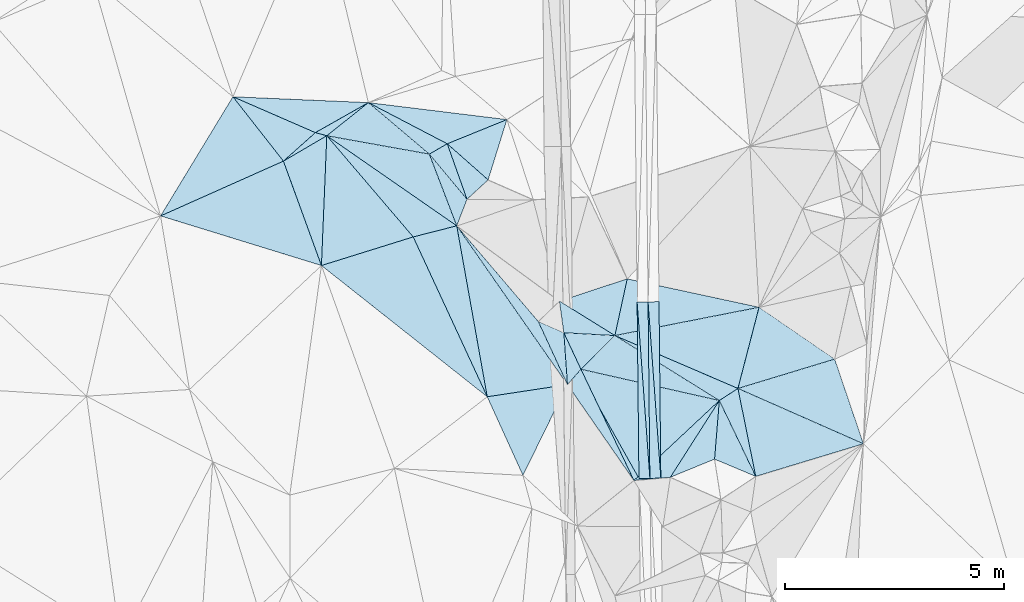
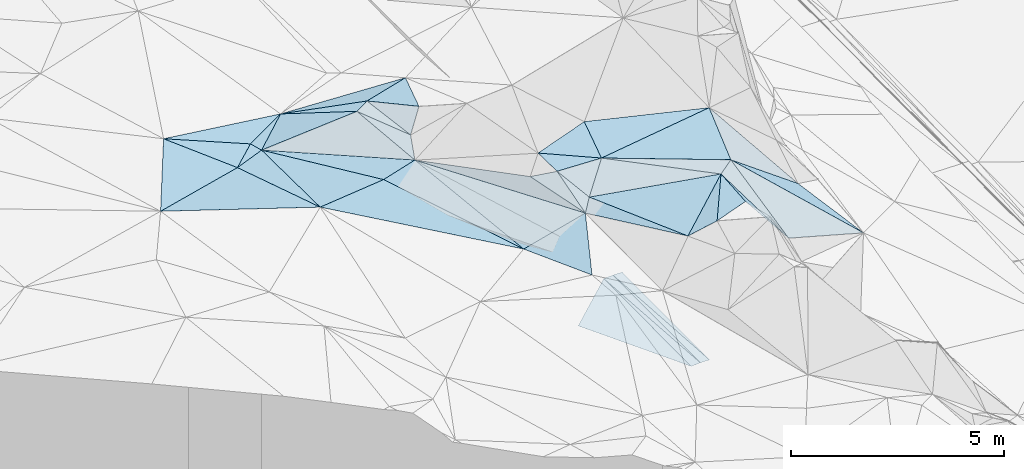
# One storey, part 17 of 275: 45 plates.
"""IFC2X3 building model written with IfcOpenShell, lengths in millimetres."""

import ifcopenshell
import ifcopenshell.guid

model = None  # the IFC model being written
_history = None  # IfcOwnerHistory: only IFC2X3 demands one
_inside = {}  # id of a spatial element -> (the spatial element, [elements in it])
_under = {}  # id of a project, library or spatial element -> (it, [spatial elements below it])
_declared = {}  # id of a project -> (the project, [libraries it declares])
_typed = {}  # id of a type object -> (the type object, [elements of that type])
_made_of = {}  # id of a material, layer set ... -> (it, [elements and type objects made of it])


def new_model(schema):
    """Start an empty IFC model of exactly this schema.

    Asked for "IFC4X3", IfcOpenShell would pick the latest addendum, in which some entities
    have other attributes; the version numbers below select the first issue.
    IFC2X3 requires an IfcOwnerHistory on every rooted entity: one is made here for all.
    """
    global model, _history
    if schema == "IFC4X3":
        model = ifcopenshell.file(schema_version=(4, 3, 0, 0))
    else:
        model = ifcopenshell.file(schema=schema)
    _inside.clear()
    _under.clear()
    _declared.clear()
    _typed.clear()
    _made_of.clear()
    _history = None
    if model.schema == "IFC2X3":
        org = make("IfcOrganization", Name="unknown")
        user = make(
            "IfcPersonAndOrganization",
            ThePerson=make("IfcPerson", FamilyName="unknown"),
            TheOrganization=org,
        )
        app = make(
            "IfcApplication",
            ApplicationDeveloper=org,
            Version="unknown",
            ApplicationFullName="unknown",
            ApplicationIdentifier="unknown",
        )
        _history = make(
            "IfcOwnerHistory",
            OwningUser=user,
            OwningApplication=app,
            ChangeAction="ADDED",
            CreationDate=0,
        )
    return model


def make(cls, **values):
    """One entity of the class cls with the attributes given. An attribute that is None is left unset."""
    return model.create_entity(
        cls, **{name: value for name, value in values.items() if value is not None}
    )


def rooted(cls, **values):
    """An entity with a GlobalId (a new one), such as an element, a storey or a relation."""
    return make(cls, GlobalId=ifcopenshell.guid.new(), OwnerHistory=_history, **values)


def si_unit(unit_type, name, prefix=None):
    """IfcSIUnit, for example si_unit("LENGTHUNIT", "METRE", prefix="MILLI")."""
    return make("IfcSIUnit", UnitType=unit_type, Prefix=prefix, Name=name)


def assignment(units):
    """IfcUnitAssignment: the units of a project."""
    return None if units is None else make("IfcUnitAssignment", Units=units)


def point(xyz):
    """IfcCartesianPoint."""
    return None if xyz is None else make("IfcCartesianPoint", Coordinates=xyz)


def direction(xyz):
    """IfcDirection."""
    return None if xyz is None else make("IfcDirection", DirectionRatios=xyz)


def frame(location, z_axis=None, x_axis=None):
    """IfcAxis2Placement3D, a coordinate frame: its origin and axes. An axis left out is left unset."""
    return make(
        "IfcAxis2Placement3D",
        Location=point(location),
        Axis=direction(z_axis),
        RefDirection=direction(x_axis),
    )


def origin_with_axes():
    """The frame at (0, 0, 0) with the z axis (0, 0, 1) and the x axis (1, 0, 0) written out."""
    return frame((0.0, 0.0, 0.0), z_axis=(0.0, 0.0, 1.0), x_axis=(1.0, 0.0, 0.0))


def place(relative_to, where):
    """IfcLocalPlacement: puts the frame where relative to a parent placement (None: the world)."""
    return make(
        "IfcLocalPlacement", PlacementRelTo=relative_to, RelativePlacement=where
    )


def context(
    kind, dimensions, precision=None, world=None, true_north=None, identifier=None
):
    """IfcGeometricRepresentationContext, for example the 3D "Model" context."""
    return make(
        "IfcGeometricRepresentationContext",
        ContextIdentifier=identifier,
        ContextType=kind,
        CoordinateSpaceDimension=dimensions,
        Precision=precision,
        WorldCoordinateSystem=world,
        TrueNorth=true_north,
    )


def subcontext(parent, identifier, kind, view, scale=None):
    """IfcGeometricRepresentationSubContext, for example "Body" below "Model"."""
    return make(
        "IfcGeometricRepresentationSubContext",
        ContextIdentifier=identifier,
        ContextType=kind,
        ParentContext=parent,
        TargetScale=scale,
        TargetView=view,
    )


def project(units=None, contexts=None):
    """IfcProject with its units and contexts."""
    return rooted(
        "IfcProject",
        Name="project",
        RepresentationContexts=contexts,
        UnitsInContext=assignment(units),
    )


def spatial(cls, under=None, at=None, **own):
    """A site, building, storey or space (cls), placed at a placement, below another one or the project."""
    s = rooted(cls, ObjectPlacement=at, **own)
    if under is not None:
        _under.setdefault(under.id(), (under, []))[1].append(s)
    return s


def polyline(points):
    """IfcPolyline through the points."""
    return make("IfcPolyline", Points=[point(p) for p in points])


def outline(outer, holes=None, kind="AREA"):
    """IfcArbitraryClosedProfileDef: a profile drawn as a closed curve; with holes, ...WithVoids."""
    if holes is None:
        return make("IfcArbitraryClosedProfileDef", ProfileType=kind, OuterCurve=outer)
    return make(
        "IfcArbitraryProfileDefWithVoids",
        ProfileType=kind,
        OuterCurve=outer,
        InnerCurves=holes,
    )


def extrude(swept, where, along, depth):
    """IfcExtrudedAreaSolid: the profile swept, set in the frame where, extruded along a direction by depth."""
    return make(
        "IfcExtrudedAreaSolid",
        SweptArea=swept,
        Position=where,
        ExtrudedDirection=direction(along),
        Depth=depth,
    )


def shape(context_of_items, identifier, shape_type, items):
    """IfcShapeRepresentation: the items that make up one representation, for example the "Body"."""
    return make(
        "IfcShapeRepresentation",
        ContextOfItems=context_of_items,
        RepresentationIdentifier=identifier,
        RepresentationType=shape_type,
        Items=items,
    )


def material(Name=None, Category=None):
    """IfcMaterial."""
    return make("IfcMaterial", Name=Name, Category=Category)


def made_of(thing, what):
    """Note that an element or type object is made of a material, layer set ...; save() writes the relation."""
    if what is not None:
        _made_of.setdefault(what.id(), (what, []))[1].append(thing)
    return thing


def type_object(cls, material=None, **own):
    """A type object (cls), such as IfcWallType, which elements share."""
    return made_of(rooted(cls, **own), material)


def element(
    cls,
    number,
    at=None,
    inside=None,
    cuts=None,
    type_object=None,
    material=None,
    context=None,
    identifier="Body",
    shape_type=None,
    held_by="IfcProductDefinitionShape",
    body=None,
    shapes=None,
    **own,
):
    """One element of the class cls, such as IfcWall. Its Tag is "e" and its number.

    at: its placement. inside: the storey or other place that contains it. cuts: it is an
    opening in that element (IfcRelVoidsElement). A single representation is given by context,
    identifier, shape_type and body (its items); several are given by shapes. held_by: the class
    of the entity that holds the representations. save() writes the other relations.
    """
    e = rooted(cls, Tag="e%d" % number, ObjectPlacement=at, **own)
    if body is not None:
        shapes = [shape(context, identifier, shape_type, body)]
    if shapes is not None:
        e.Representation = make(held_by, Representations=shapes)
    if inside is not None:
        _inside.setdefault(inside.id(), (inside, []))[1].append(e)
    if cuts is not None:
        rooted(
            "IfcRelVoidsElement", RelatingBuildingElement=cuts, RelatedOpeningElement=e
        )
    if type_object is not None:
        _typed.setdefault(type_object.id(), (type_object, []))[1].append(e)
    return made_of(e, material)


def aggregate(whole, parts):
    """IfcRelAggregates: a whole, such as a stair, and the parts it consists of."""
    return rooted("IfcRelAggregates", RelatingObject=whole, RelatedObjects=parts)


def save(model, path):
    """Write the relations noted so far, then the file.

    IfcRelAggregates (storeys below a building ...), IfcRelContainedInSpatialStructure (elements
    in a storey), IfcRelDefinesByType, IfcRelAssociatesMaterial and IfcRelDeclares: one each for
    every whole, place, type object, material and project.
    """
    for whole, parts in _under.values():
        aggregate(whole, parts)
    for where, things in _inside.values():
        rooted(
            "IfcRelContainedInSpatialStructure",
            RelatedElements=things,
            RelatingStructure=where,
        )
    for kind, things in _typed.values():
        rooted("IfcRelDefinesByType", RelatedObjects=things, RelatingType=kind)
    for what, things in _made_of.values():
        rooted("IfcRelAssociatesMaterial", RelatedObjects=things, RelatingMaterial=what)
    for by, libraries in _declared.values():
        rooted("IfcRelDeclares", RelatingContext=by, RelatedDefinitions=libraries)
    model.write(path)


model = new_model("IFC2X3")

# Units and contexts
model_context = context("Model", 3, precision=1e-05, world=origin_with_axes())
body_context = subcontext(model_context, "Body", "Model", "MODEL_VIEW")
ifc_project = project(units=[si_unit("LENGTHUNIT", "METRE", prefix="MILLI"), si_unit("AREAUNIT", "SQUARE_METRE"), si_unit("VOLUMEUNIT", "CUBIC_METRE"), si_unit("MASSUNIT", "GRAM", prefix="KILO"), si_unit("TIMEUNIT", "SECOND"), si_unit("PLANEANGLEUNIT", "RADIAN"), si_unit("SOLIDANGLEUNIT", "STERADIAN"), si_unit("THERMODYNAMICTEMPERATUREUNIT", "DEGREE_CELSIUS"), si_unit("LUMINOUSINTENSITYUNIT", "LUMEN")], contexts=[model_context])

# Site, building, storey
site_placement = place(None, origin_with_axes())
site = spatial("IfcSite", under=ifc_project, at=site_placement, CompositionType="ELEMENT")
building_placement = place(site_placement, origin_with_axes())
building = spatial("IfcBuilding", under=site, at=building_placement, Name="Undefined", CompositionType="ELEMENT")
storey_placement = place(building_placement, origin_with_axes())
storey = spatial("IfcBuildingStorey", under=building, at=storey_placement, Name="Undefined", CompositionType="ELEMENT", Elevation=0.0)

# Plates
ifc_material = material()
plate_type_1 = type_object("IfcPlateType", PredefinedType="NOTDEFINED")
plate_1_placement = place(storey_placement, frame((-103797.27773014, 22771.6117747308, 41682.3317325591), z_axis=(0.0497178700375145, 0.0212183839276351, -0.998537887905327), x_axis=(0.998702732628919, 0.00995428809633691, 0.0499376009438284)))
element("IfcPlate", 1, at=plate_1_placement, inside=storey, type_object=plate_type_1, material=ifc_material, Name="00_PR", context=body_context, shape_type="SweptSolid", body=[
    extrude(outline(polyline([(0.0, 0.0), (250.31233215332, -1.60071067512035e-10), (247.495971679688, 4029.3076171875), (0.0, 0.0)])), frame((-8.85201319254618e-08, 2.18876761149539e-07, -0.5000001331573), z_axis=(0.0, 0.0, 1.0), x_axis=(1.0, 0.0, 0.0)), (0.0, 0.0, 1.0), 1.0),
])
plate_2_placement = place(storey_placement, frame((-103797.27773014, 22771.6117747308, 41682.3317325591), z_axis=(0.0497040755648301, 0.0212173967946031, -0.998538595621374), x_axis=(0.0722075051416282, -0.997234414378118, -0.0175954250063349)))
element("IfcPlate", 2, at=plate_2_placement, inside=storey, type_object=plate_type_1, material=ifc_material, Name="00_PR", context=body_context, shape_type="SweptSolid", body=[
    extrude(outline(polyline([(0.0, 0.0), (4036.90161132813, 5.86442183703184e-09), (4021.72241210938, 249.851547241211), (0.0, 0.0)])), frame((-8.85201319254618e-08, 2.18876761149539e-07, -0.5000001331573), z_axis=(0.0, 0.0, 1.0), x_axis=(1.0, 0.0, 0.0)), (0.0, 0.0, 1.0), 1.0),
])
plate_3_placement = place(storey_placement, frame((-103255.832351357, 18748.5334819918, 41606.3002082546), z_axis=(-0.0202111180941592, 0.020519550069768, -0.999585143332132), x_axis=(-0.999743497927945, -0.0106347531094472, 0.0199960090292572)))
element("IfcPlate", 3, at=plate_3_placement, inside=storey, type_object=plate_type_1, material=ifc_material, Name="00_PR", context=body_context, shape_type="SweptSolid", body=[
    extrude(outline(polyline([(0.0, 0.0), (250.049896240234, -1.4915713109076e-09), (250.377243041992, 4029.30859375), (0.0, 0.0)])), frame((-8.85201319254618e-08, 2.18876761149539e-07, -0.5000001331573), z_axis=(0.0, 0.0, 1.0), x_axis=(1.0, 0.0, 0.0)), (0.0, 0.0, 1.0), 1.0),
])
plate_4_placement = place(storey_placement, frame((-103547.325030308, 22774.1030868264, 41694.8312079371), z_axis=(-0.0201973358097432, 0.0205205545026295, -0.999585401288501), x_axis=(0.999750363781903, 0.00996840112044763, -0.0199960270317622)))
element("IfcPlate", 4, at=plate_4_placement, inside=storey, type_object=plate_type_1, material=ifc_material, Name="00_PR", context=body_context, shape_type="SweptSolid", body=[
    extrude(outline(polyline([(0.0, 0.0), (250.049682617188, -4.69299266114831e-10), (253.06169128418, 4029.14086914063), (0.0, 0.0)])), frame((-8.85201319254618e-08, 2.18876761149539e-07, -0.5000001331573), z_axis=(0.0, 0.0, 1.0), x_axis=(1.0, 0.0, 0.0)), (0.0, 0.0, 1.0), 1.0),
])
plate_type_2 = type_object("IfcPlateType", PredefinedType="NOTDEFINED")
plate_5_placement = place(storey_placement, frame((-109930.081243127, 27320.2990682727, 45789.5211855592), z_axis=(0.0147514530825783, -0.287693945136406, -0.957608786803778), x_axis=(0.991249788035163, -0.121431694829454, 0.0517513401864353)))
element("IfcPlate", 5, at=plate_5_placement, inside=storey, type_object=plate_type_2, material=ifc_material, Name="00", context=body_context, shape_type="SweptSolid", body=[
    extrude(outline(polyline([(0.0, 0.0), (3188.3232421875, 1.9874278223142e-08), (1913.97717285156, 744.389831542969), (0.0, 0.0)])), frame((-8.85201319254618e-08, 2.18876761149539e-07, -0.5000001331573), z_axis=(0.0, 0.0, 1.0), x_axis=(1.0, 0.0, 0.0)), (0.0, 0.0, 1.0), 1.0),
])
plate_type_3 = type_object("IfcPlateType", PredefinedType="NOTDEFINED")
plate_6_placement = place(storey_placement, frame((-108907.341038991, 24255.2884919906, 45409.5034933445), z_axis=(0.0297802562647828, 0.114492130276178, -0.992977687786401), x_axis=(0.967393542202773, 0.24667519173966, 0.0574550631761279)))
element("IfcPlate", 6, at=plate_6_placement, inside=storey, type_object=plate_type_3, material=ifc_material, Name="00", context=body_context, shape_type="SweptSolid", body=[
    extrude(outline(polyline([(0.0, 0.0), (1026.88952636719, -5.36965671926737e-09), (713.163391113281, 3974.11596679688), (0.0, 0.0)])), frame((-8.85201319254618e-08, 2.18876761149539e-07, -0.5000001331573), z_axis=(0.0, 0.0, 1.0), x_axis=(1.0, 0.0, 0.0)), (0.0, 0.0, 1.0), 1.0),
])
plate_type_4 = type_object("IfcPlateType", PredefinedType="NOTDEFINED")
plate_7_placement = place(storey_placement, frame((-104304.153658088, 22004.3723327045, 45779.5053342272), z_axis=(-0.0564691182503857, 0.134573435854688, -0.989293297787005), x_axis=(0.210493026376428, 0.970207075878639, 0.119962143036511)))
element("IfcPlate", 7, at=plate_7_placement, inside=storey, type_object=plate_type_4, material=ifc_material, Name="00", context=body_context, shape_type="SweptSolid", body=[
    extrude(outline(polyline([(0.0, 0.0), (1333.75415039063, 1.87719706445932e-09), (1306.68762207031, 3089.185546875), (0.0, 0.0)])), frame((-8.85201319254618e-08, 2.18876761149539e-07, -0.5000001331573), z_axis=(0.0, 0.0, 1.0), x_axis=(1.0, 0.0, 0.0)), (0.0, 0.0, 1.0), 1.0),
])
plate_type_5 = type_object("IfcPlateType", PredefinedType="NOTDEFINED")
plate_8_placement = place(storey_placement, frame((-105263.895198522, 21434.0511645319, 41654.8061091048), z_axis=(-0.000141855409344872, 0.0207296288161507, -0.999785108093828), x_axis=(0.738791232216663, 0.673791703351115, 0.0138656299888626)))
element("IfcPlate", 8, at=plate_8_placement, inside=storey, type_object=plate_type_5, material=ifc_material, Name="00_PR", context=body_context, shape_type="SweptSolid", body=[
    extrude(outline(polyline([(0.0, 0.0), (1985.12438964844, 6.89760781824589e-09), (-699.66748046875, 3004.7578125), (0.0, 0.0)])), frame((-8.85201319254618e-08, 2.18876761149539e-07, -0.5000001331573), z_axis=(0.0, 0.0, 1.0), x_axis=(1.0, 0.0, 0.0)), (0.0, 0.0, 1.0), 1.0),
])
plate_type_6 = type_object("IfcPlateType", PredefinedType="NOTDEFINED")
plate_9_placement = place(storey_placement, frame((-105079.315226752, 21235.3865758794, 45399.5459398077), z_axis=(0.0308042153478738, 0.417614998518534, -0.90810176375182), x_axis=(-0.393508522175019, 0.8402277059103, 0.373052871851092)))
element("IfcPlate", 9, at=plate_9_placement, inside=storey, type_object=plate_type_6, material=ifc_material, Name="00", context=body_context, shape_type="SweptSolid", body=[
    extrude(outline(polyline([(0.0, 0.0), (991.816528320313, 1.52795109897852e-09), (482.952239990234, 1050.55090332031), (0.0, 0.0)])), frame((-8.85201319254618e-08, 2.18876761149539e-07, -0.5000001331573), z_axis=(0.0, 0.0, 1.0), x_axis=(1.0, 0.0, 0.0)), (0.0, 0.0, 1.0), 1.0),
])
plate_type_7 = type_object("IfcPlateType", PredefinedType="NOTDEFINED")
plate_10_placement = place(storey_placement, frame((-110879.685752144, 26565.0034138816, 45542.5022801309), z_axis=(0.0365455944571772, 0.088525263264373, -0.995403283744707), x_axis=(0.821603632336987, -0.569690452418268, -0.0205002379044083)))
element("IfcPlate", 10, at=plate_10_placement, inside=storey, type_object=plate_type_7, material=ifc_material, Name="00", context=body_context, shape_type="SweptSolid", body=[
    extrude(outline(polyline([(0.0, 0.0), (3609.71435546875, -2.48110154643655e-09), (2939.044921875, 777.627502441406), (0.0, 0.0)])), frame((-8.85201319254618e-08, 2.18876761149539e-07, -0.5000001331573), z_axis=(0.0, 0.0, 1.0), x_axis=(1.0, 0.0, 0.0)), (0.0, 0.0, 1.0), 1.0),
])
plate_type_8 = type_object("IfcPlateType", PredefinedType="NOTDEFINED")
plate_11_placement = place(storey_placement, frame((-107913.899447201, 24508.6026195852, 45468.5065445479), z_axis=(0.100497845191069, 0.126436860621807, -0.98687076326541), x_axis=(0.571345167581345, -0.819374740840552, -0.0467945889385024)))
element("IfcPlate", 11, at=plate_11_placement, inside=storey, type_object=plate_type_8, material=ifc_material, Name="00", context=body_context, shape_type="SweptSolid", body=[
    extrude(outline(polyline([(0.0, 0.0), (4423.58837890625, -1.65600795298815e-08), (3614.75024414063, 1680.95300292969), (0.0, 0.0)])), frame((-8.85201319254618e-08, 2.18876761149539e-07, -0.5000001331573), z_axis=(0.0, 0.0, 1.0), x_axis=(1.0, 0.0, 0.0)), (0.0, 0.0, 1.0), 1.0),
])
plate_type_9 = type_object("IfcPlateType", PredefinedType="NOTDEFINED")
plate_12_placement = place(storey_placement, frame((-109930.130831956, 27320.5316971504, 45789.5097305416), z_axis=(-0.0842540870524157, 0.17753061392784, -0.980501978546381), x_axis=(-0.870238187024887, -0.492421302785967, -0.0143790961541045)))
element("IfcPlate", 12, at=plate_12_placement, inside=storey, type_object=plate_type_9, material=ifc_material, Name="00", context=body_context, shape_type="SweptSolid", body=[
    extrude(outline(polyline([(0.0, 0.0), (1390.90795898438, 3.91446519643068e-09), (2620.81689453125, 1672.01208496094), (0.0, 0.0)])), frame((-8.85201319254618e-08, 2.18876761149539e-07, -0.5000001331573), z_axis=(0.0, 0.0, 1.0), x_axis=(1.0, 0.0, 0.0)), (0.0, 0.0, 1.0), 1.0),
])
plate_type_10 = type_object("IfcPlateType", PredefinedType="NOTDEFINED")
plate_13_placement = place(storey_placement, frame((-108130.331021472, 26381.0442748659, 46099.5678947269), z_axis=(0.343295792660948, 0.367861310458817, -0.864190982948106), x_axis=(0.749561558969627, -0.661739390755027, 0.0160763191741436)))
element("IfcPlate", 13, at=plate_13_placement, inside=storey, type_object=plate_type_10, material=ifc_material, Name="00", context=body_context, shape_type="SweptSolid", body=[
    extrude(outline(polyline([(0.0, 0.0), (1244.06591796875, -2.2810127120465e-09), (1169.55212402344, 753.224853515625), (0.0, 0.0)])), frame((-8.85201319254618e-08, 2.18876761149539e-07, -0.5000001331573), z_axis=(0.0, 0.0, 1.0), x_axis=(1.0, 0.0, 0.0)), (0.0, 0.0, 1.0), 1.0),
])
plate_type_11 = type_object("IfcPlateType", PredefinedType="NOTDEFINED")
plate_14_placement = place(storey_placement, frame((-101090.135668084, 18789.5107489817, 44309.6787832914), z_axis=(-0.765657164249471, 0.0331222328474814, -0.642395535884751), x_axis=(-0.614498423351028, 0.257568851664282, 0.745687584951932)))
element("IfcPlate", 14, at=plate_14_placement, inside=storey, type_object=plate_type_11, material=ifc_material, Name="00", context=body_context, shape_type="SweptSolid", body=[
    extrude(outline(polyline([(0.0, 0.0), (1528.79040527344, 7.76708475314081e-10), (1762.17749023438, 1323.30285644531), (0.0, 0.0)])), frame((-8.85201319254618e-08, 2.18876761149539e-07, -0.5000001331573), z_axis=(0.0, 0.0, 1.0), x_axis=(1.0, 0.0, 0.0)), (0.0, 0.0, 1.0), 1.0),
])
plate_type_12 = type_object("IfcPlateType", PredefinedType="NOTDEFINED")
plate_15_placement = place(storey_placement, frame((-110879.933986391, 26565.2331096824, 45542.6506035165), z_axis=(-0.459922916450668, 0.547915284329686, -0.698755860169653), x_axis=(-0.850461021579642, -0.498077556508428, 0.169218197828443)))
element("IfcPlate", 15, at=plate_15_placement, inside=storey, type_object=plate_type_12, material=ifc_material, Name="00", context=body_context, shape_type="SweptSolid", body=[
    extrude(outline(polyline([(0.0, 0.0), (1164.17736816406, -1.39698386192322e-09), (225.067932128906, 271.796661376953), (0.0, 0.0)])), frame((-8.85201319254618e-08, 2.18876761149539e-07, -0.5000001331573), z_axis=(0.0, 0.0, 1.0), x_axis=(1.0, 0.0, 0.0)), (0.0, 0.0, 1.0), 1.0),
])
plate_type_13 = type_object("IfcPlateType", PredefinedType="NOTDEFINED")
plate_16_placement = place(storey_placement, frame((-110879.588016769, 26564.9722646433, 45542.5138045271), z_axis=(0.23204775886243, 0.0262275979280195, -0.97235073441318), x_axis=(0.766833378297704, 0.610068273171838, 0.199457444076829)))
element("IfcPlate", 16, at=plate_16_placement, inside=storey, type_object=plate_type_13, material=ifc_material, Name="00", context=body_context, shape_type="SweptSolid", body=[
    extrude(outline(polyline([(0.0, 0.0), (1238.359375, -7.27595761418343e-09), (1647.00085449219, 1798.99890136719), (0.0, 0.0)])), frame((-8.85201319254618e-08, 2.18876761149539e-07, -0.5000001331573), z_axis=(0.0, 0.0, 1.0), x_axis=(1.0, 0.0, 0.0)), (0.0, 0.0, 1.0), 1.0),
])
plate_type_14 = type_object("IfcPlateType", PredefinedType="NOTDEFINED")
plate_17_placement = place(storey_placement, frame((-113022.420535324, 27454.6257207435, 46079.5081555934), z_axis=(-0.0956270690329775, 0.15259119283282, -0.983652068334134), x_axis=(0.906640227347292, -0.394585499414957, -0.149351202898069)))
element("IfcPlate", 17, at=plate_17_placement, inside=storey, type_object=plate_type_14, material=ifc_material, Name="00", context=body_context, shape_type="SweptSolid", body=[
    extrude(outline(polyline([(0.0, 0.0), (2075.64453125, 9.77161107584834e-09), (1675.57592773438, 892.045532226563), (0.0, 0.0)])), frame((-8.85201319254618e-08, 2.18876761149539e-07, -0.5000001331573), z_axis=(0.0, 0.0, 1.0), x_axis=(1.0, 0.0, 0.0)), (0.0, 0.0, 1.0), 1.0),
])
plate_type_15 = type_object("IfcPlateType", PredefinedType="NOTDEFINED")
plate_18_placement = place(storey_placement, frame((-101089.816389005, 18789.7342445799, 44309.5660413622), z_axis=(-0.127294535058184, 0.48015306336127, -0.867899266671604), x_axis=(-0.377187020037007, 0.785844795614425, 0.49007949265535)))
element("IfcPlate", 18, at=plate_18_placement, inside=storey, type_object=plate_type_15, material=ifc_material, Name="00", context=body_context, shape_type="SweptSolid", body=[
    extrude(outline(polyline([(0.0, 0.0), (2203.72412109375, -5.86442183703184e-09), (2303.91821289063, 504.441436767578), (0.0, 0.0)])), frame((-8.85201319254618e-08, 2.18876761149539e-07, -0.5000001331573), z_axis=(0.0, 0.0, 1.0), x_axis=(1.0, 0.0, 0.0)), (0.0, 0.0, 1.0), 1.0),
])
plate_type_16 = type_object("IfcPlateType", PredefinedType="NOTDEFINED")
plate_19_placement = place(storey_placement, frame((-105469.636358051, 22068.7253944912, 45769.5403022276), z_axis=(-0.0349578154423935, 0.391822210794227, -0.91937658566434), x_axis=(0.393508522173624, -0.840227705911354, -0.373052871850189)))
element("IfcPlate", 19, at=plate_19_placement, inside=storey, type_object=plate_type_16, material=ifc_material, Name="00", context=body_context, shape_type="SweptSolid", body=[
    extrude(outline(polyline([(0.0, 0.0), (991.816528320313, 1.52795109897852e-09), (1217.50341796875, 431.100250244141), (0.0, 0.0)])), frame((-8.85201319254618e-08, 2.18876761149539e-07, -0.5000001331573), z_axis=(0.0, 0.0, 1.0), x_axis=(1.0, 0.0, 0.0)), (0.0, 0.0, 1.0), 1.0),
])
plate_type_17 = type_object("IfcPlateType", PredefinedType="NOTDEFINED")
plate_20_placement = place(storey_placement, frame((-105469.458880417, 22068.7256209938, 45769.5687935075), z_axis=(0.319996059605678, 0.392275427398409, -0.862393477999593), x_axis=(0.0643131142142744, -0.917150052991363, -0.393318704917528)))
element("IfcPlate", 20, at=plate_20_placement, inside=storey, type_object=plate_type_17, material=ifc_material, Name="00", context=body_context, shape_type="SweptSolid", body=[
    extrude(outline(polyline([(0.0, 0.0), (1291.57348632813, 8.29459168016911e-10), (-232.971649169922, 601.268859863281), (0.0, 0.0)])), frame((-8.85201319254618e-08, 2.18876761149539e-07, -0.5000001331573), z_axis=(0.0, 0.0, 1.0), x_axis=(1.0, 0.0, 0.0)), (0.0, 0.0, 1.0), 1.0),
])
plate_type_18 = type_object("IfcPlateType", PredefinedType="NOTDEFINED")
plate_21_placement = place(storey_placement, frame((-101920.903596433, 20521.2068527523, 45389.5095928699), z_axis=(0.130552978590971, -0.144892033975627, -0.980796726274834), x_axis=(-0.537083290039444, -0.841870220336416, 0.052877893973957)))
element("IfcPlate", 21, at=plate_21_placement, inside=storey, type_object=plate_type_18, material=ifc_material, Name="00", context=body_context, shape_type="SweptSolid", body=[
    extrude(outline(polyline([(0.0, 0.0), (2080.26440429688, 6.12635631114244e-09), (2582.70043945313, 674.209106445313), (0.0, 0.0)])), frame((-8.85201319254618e-08, 2.18876761149539e-07, -0.5000001331573), z_axis=(0.0, 0.0, 1.0), x_axis=(1.0, 0.0, 0.0)), (0.0, 0.0, 1.0), 1.0),
])
plate_type_19 = type_object("IfcPlateType", PredefinedType="NOTDEFINED")
plate_22_placement = place(storey_placement, frame((-101496.003058315, 20796.7613648539, 45479.5205877103), z_axis=(0.0194456370223509, 0.283391432257298, -0.958807156483488), x_axis=(-0.826287573504059, -0.53537372689382, -0.17499662403771)))
element("IfcPlate", 22, at=plate_22_placement, inside=storey, type_object=plate_type_19, material=ifc_material, Name="00", context=body_context, shape_type="SweptSolid", body=[
    extrude(outline(polyline([(0.0, 0.0), (514.295654296875, -2.02271621674299e-09), (1621.24645996094, 2608.74682617188), (0.0, 0.0)])), frame((-8.85201319254618e-08, 2.18876761149539e-07, -0.5000001331573), z_axis=(0.0, 0.0, 1.0), x_axis=(1.0, 0.0, 0.0)), (0.0, 0.0, 1.0), 1.0),
])
plate_type_20 = type_object("IfcPlateType", PredefinedType="NOTDEFINED")
plate_23_placement = place(storey_placement, frame((-111002.358875311, 23602.3851867569, 45749.5062439501), z_axis=(-0.146875791979332, -0.0576198057241109, -0.987475295751119), x_axis=(-0.94821812594204, 0.292425989278573, 0.123973490833372)))
element("IfcPlate", 23, at=plate_23_placement, inside=storey, type_object=plate_type_20, material=ifc_material, Name="00", context=body_context, shape_type="SweptSolid", body=[
    extrude(outline(polyline([(0.0, 0.0), (3871.79541015625, -1.9117578631267e-08), (1518.10705566406, 2031.07141113281), (0.0, 0.0)])), frame((-8.85201319254618e-08, 2.18876761149539e-07, -0.5000001331573), z_axis=(0.0, 0.0, 1.0), x_axis=(1.0, 0.0, 0.0)), (0.0, 0.0, 1.0), 1.0),
])
plate_type_21 = type_object("IfcPlateType", PredefinedType="NOTDEFINED")
plate_24_placement = place(storey_placement, frame((-108540.110380453, 26145.2787644838, 46089.5393818126), z_axis=(0.0809476174352155, 0.380535520528819, -0.921216695923073), x_axis=(0.62009230105507, -0.742832113774932, -0.252360830789753)))
element("IfcPlate", 24, at=plate_24_placement, inside=storey, type_object=plate_type_21, material=ifc_material, Name="00", context=body_context, shape_type="SweptSolid", body=[
    extrude(outline(polyline([(0.0, 0.0), (1386.90307617188, -5.04223862662911e-09), (1760.69982910156, 596.655578613281), (0.0, 0.0)])), frame((-8.85201319254618e-08, 2.18876761149539e-07, -0.5000001331573), z_axis=(0.0, 0.0, 1.0), x_axis=(1.0, 0.0, 0.0)), (0.0, 0.0, 1.0), 1.0),
])
plate_type_22 = type_object("IfcPlateType", PredefinedType="NOTDEFINED")
plate_25_placement = place(storey_placement, frame((-105386.246613009, 20884.1952027084, 45261.6811611552), z_axis=(0.614310812127051, 0.464772088016294, -0.637659103522233), x_axis=(-0.571345167250183, 0.819374741076193, 0.0467945888557784)))
element("IfcPlate", 25, at=plate_25_placement, inside=storey, type_object=plate_type_22, material=ifc_material, Name="00", context=body_context, shape_type="SweptSolid", body=[
    extrude(outline(polyline([(0.0, 0.0), (4423.58837890625, -1.65600795298815e-08), (1580.19152832031, 434.461303710938), (0.0, 0.0)])), frame((-8.85201319254618e-08, 2.18876761149539e-07, -0.5000001331573), z_axis=(0.0, 0.0, 1.0), x_axis=(1.0, 0.0, 0.0)), (0.0, 0.0, 1.0), 1.0),
])
plate_type_23 = type_object("IfcPlateType", PredefinedType="NOTDEFINED")
plate_26_placement = place(storey_placement, frame((-108130.535552257, 26380.8110356709, 46099.5035156864), z_axis=(-0.0657674899925876, -0.0986185176775058, -0.992949658961201), x_axis=(0.922083729873517, 0.374310795116449, -0.0982498028590079)))
element("IfcPlate", 26, at=plate_26_placement, inside=storey, type_object=plate_type_23, material=ifc_material, Name="00", context=body_context, shape_type="SweptSolid", body=[
    extrude(outline(polyline([(0.0, 0.0), (1475.82995605469, 3.79077391698956e-09), (549.731384277344, 1116.01770019531), (0.0, 0.0)])), frame((-8.85201319254618e-08, 2.18876761149539e-07, -0.5000001331573), z_axis=(0.0, 0.0, 1.0), x_axis=(1.0, 0.0, 0.0)), (0.0, 0.0, 1.0), 1.0),
])
plate_type_24 = type_object("IfcPlateType", PredefinedType="NOTDEFINED")
plate_27_placement = place(storey_placement, frame((-108540.100598361, 26145.0220892778, 46089.506974562), z_axis=(0.100511480931647, -0.132814978975605, -0.986031248774924), x_axis=(-0.753424632379757, 0.637108360112346, -0.162616914244445)))
element("IfcPlate", 27, at=plate_27_placement, inside=storey, type_object=plate_type_24, material=ifc_material, Name="00", context=body_context, shape_type="SweptSolid", body=[
    extrude(outline(polyline([(0.0, 0.0), (1844.82653808594, 2.33558239415288e-09), (-160.052993774414, 444.840454101563), (0.0, 0.0)])), frame((-8.85201319254618e-08, 2.18876761149539e-07, -0.5000001331573), z_axis=(0.0, 0.0, 1.0), x_axis=(1.0, 0.0, 0.0)), (0.0, 0.0, 1.0), 1.0),
])
plate_type_25 = type_object("IfcPlateType", PredefinedType="NOTDEFINED")
plate_28_placement = place(storey_placement, frame((-101014.47920533, 22649.8239079539, 45679.6489739753), z_axis=(-0.667102755879559, 0.249240182445991, -0.70203507359119), x_axis=(0.587741455013931, -0.402960536824249, -0.701557401657498)))
element("IfcPlate", 28, at=plate_28_placement, inside=storey, type_object=plate_type_25, material=ifc_material, Name="00", context=body_context, shape_type="SweptSolid", body=[
    extrude(outline(polyline([(0.0, 0.0), (2936.32421875, 8.70204530656338e-09), (603.816162109375, 1827.97863769531), (0.0, 0.0)])), frame((-8.85201319254618e-08, 2.18876761149539e-07, -0.5000001331573), z_axis=(0.0, 0.0, 1.0), x_axis=(1.0, 0.0, 0.0)), (0.0, 0.0, 1.0), 1.0),
])
plate_type_26 = type_object("IfcPlateType", PredefinedType="NOTDEFINED")
plate_29_placement = place(storey_placement, frame((-107680.198771697, 25114.9698268984, 45739.5171916752), z_axis=(-0.11160899611204, 0.234872807703849, -0.965597326108649), x_axis=(-0.62009230105226, 0.742832113774822, 0.252360830796984)))
element("IfcPlate", 29, at=plate_29_placement, inside=storey, type_object=plate_type_26, material=ifc_material, Name="00", context=body_context, shape_type="SweptSolid", body=[
    extrude(outline(polyline([(0.0, 0.0), (1386.90307617188, -5.04223862662911e-09), (1310.5458984375, 466.550720214844), (0.0, 0.0)])), frame((-8.85201319254618e-08, 2.18876761149539e-07, -0.5000001331573), z_axis=(0.0, 0.0, 1.0), x_axis=(1.0, 0.0, 0.0)), (0.0, 0.0, 1.0), 1.0),
])
plate_type_27 = type_object("IfcPlateType", PredefinedType="NOTDEFINED")
plate_30_placement = place(storey_placement, frame((-101014.172584788, 22649.7597795701, 45679.5043954967), z_axis=(-0.0538609229118584, 0.120983602399694, -0.991192195758964), x_axis=(-0.250304542727324, -0.96257707167385, -0.103889445940682)))
element("IfcPlate", 30, at=plate_30_placement, inside=storey, type_object=plate_type_27, material=ifc_material, Name="00", context=body_context, shape_type="SweptSolid", body=[
    extrude(outline(polyline([(0.0, 0.0), (1925.12341308594, -1.58615875989199e-09), (1434.349609375, 3032.01928710938), (0.0, 0.0)])), frame((-8.85201319254618e-08, 2.18876761149539e-07, -0.5000001331573), z_axis=(0.0, 0.0, 1.0), x_axis=(1.0, 0.0, 0.0)), (0.0, 0.0, 1.0), 1.0),
])
plate_type_28 = type_object("IfcPlateType", PredefinedType="NOTDEFINED")
plate_31_placement = place(storey_placement, frame((-98632.1788923703, 19533.8789655014, 43149.6155547465), z_axis=(-0.638696688666169, -0.0299727273964163, -0.768874616240705), x_axis=(-0.733994222045162, 0.323597692868391, 0.597107205763397)))
element("IfcPlate", 31, at=plate_31_placement, inside=storey, type_object=plate_type_28, material=ifc_material, Name="00", context=body_context, shape_type="SweptSolid", body=[
    extrude(outline(polyline([(0.0, 0.0), (3902.14672851563, -7.28869054000825e-09), (1387.87707519531, 1568.61315917969), (0.0, 0.0)])), frame((-8.85201319254618e-08, 2.18876761149539e-07, -0.5000001331573), z_axis=(0.0, 0.0, 1.0), x_axis=(1.0, 0.0, 0.0)), (0.0, 0.0, 1.0), 1.0),
])
plate_type_29 = type_object("IfcPlateType", PredefinedType="NOTDEFINED")
plate_32_placement = place(storey_placement, frame((-104023.38384595, 23298.3849989559, 45939.5039079644), z_axis=(-0.0089119957161148, 0.124610752799994, -0.99216568002475), x_axis=(-0.210493026771281, -0.970207075803952, -0.119962142947723)))
element("IfcPlate", 32, at=plate_32_placement, inside=storey, type_object=plate_type_29, material=ifc_material, Name="00", context=body_context, shape_type="SweptSolid", body=[
    extrude(outline(polyline([(0.0, 0.0), (1333.75415039063, 1.87719706445932e-09), (825.039611816406, 1404.21142578125), (0.0, 0.0)])), frame((-8.85201319254618e-08, 2.18876761149539e-07, -0.5000001331573), z_axis=(0.0, 0.0, 1.0), x_axis=(1.0, 0.0, 0.0)), (0.0, 0.0, 1.0), 1.0),
])
plate_type_30 = type_object("IfcPlateType", PredefinedType="NOTDEFINED")
plate_33_placement = place(storey_placement, frame((-105569.729146537, 22789.7064702731, 45889.5070495485), z_axis=(0.0176345985330013, 0.166512819381609, -0.985881586153311), x_axis=(0.847402914760036, -0.525817221660593, -0.0736515407939972)))
element("IfcPlate", 33, at=plate_33_placement, inside=storey, type_object=plate_type_30, material=ifc_material, Name="00", context=body_context, shape_type="SweptSolid", body=[
    extrude(outline(polyline([(0.0, 0.0), (1493.51928710938, -8.33824742585421e-09), (472.842895507813, 566.409362792969), (0.0, 0.0)])), frame((-8.85201319254618e-08, 2.18876761149539e-07, -0.5000001331573), z_axis=(0.0, 0.0, 1.0), x_axis=(1.0, 0.0, 0.0)), (0.0, 0.0, 1.0), 1.0),
])
plate_type_31 = type_object("IfcPlateType", PredefinedType="NOTDEFINED")
plate_34_placement = place(storey_placement, frame((-101496.255509605, 20796.8021001935, 45479.6027489281), z_axis=(-0.485458573045376, 0.364862265259993, -0.794484424797676), x_axis=(0.733994222045542, -0.323597692871484, -0.597107205761254)))
element("IfcPlate", 34, at=plate_34_placement, inside=storey, type_object=plate_type_31, material=ifc_material, Name="00", context=body_context, shape_type="SweptSolid", body=[
    extrude(outline(polyline([(0.0, 0.0), (3902.14672851563, -7.28869054000825e-09), (1646.30908203125, 1688.83581542969), (0.0, 0.0)])), frame((-8.85201319254618e-08, 2.18876761149539e-07, -0.5000001331573), z_axis=(0.0, 0.0, 1.0), x_axis=(1.0, 0.0, 0.0)), (0.0, 0.0, 1.0), 1.0),
])
plate_type_32 = type_object("IfcPlateType", PredefinedType="NOTDEFINED")
plate_35_placement = place(storey_placement, frame((-104304.084506412, 22004.492089715, 45779.5381011065), z_axis=(0.0816398221271153, 0.374123055380163, -0.923778587582579), x_axis=(0.84095052434794, -0.523319089028387, -0.137620298856764)))
element("IfcPlate", 35, at=plate_35_placement, inside=storey, type_object=plate_type_32, material=ifc_material, Name="00", context=body_context, shape_type="SweptSolid", body=[
    extrude(outline(polyline([(0.0, 0.0), (2833.88427734375, 1.50466803461313e-08), (-197.114608764648, 1139.31811523438), (0.0, 0.0)])), frame((-8.85201319254618e-08, 2.18876761149539e-07, -0.5000001331573), z_axis=(0.0, 0.0, 1.0), x_axis=(1.0, 0.0, 0.0)), (0.0, 0.0, 1.0), 1.0),
])
plate_type_33 = type_object("IfcPlateType", PredefinedType="NOTDEFINED")
plate_36_placement = place(storey_placement, frame((-101920.984976141, 20521.2582113564, 45389.5006956068), z_axis=(-0.0322075351186017, -0.0421742680889733, -0.998591010270343), x_axis=(-0.0805395788170259, -0.995750761564469, 0.0446519550272486)))
element("IfcPlate", 36, at=plate_36_placement, inside=storey, type_object=plate_type_33, material=ifc_material, Name="00", context=body_context, shape_type="SweptSolid", body=[
    extrude(outline(polyline([(0.0, 0.0), (1343.72619628906, 7.13043846189976e-10), (1838.76745605469, 972.848449707031), (0.0, 0.0)])), frame((-8.85201319254618e-08, 2.18876761149539e-07, -0.5000001331573), z_axis=(0.0, 0.0, 1.0), x_axis=(1.0, 0.0, 0.0)), (0.0, 0.0, 1.0), 1.0),
])
plate_type_34 = type_object("IfcPlateType", PredefinedType="NOTDEFINED")
plate_37_placement = place(storey_placement, frame((-103869.958325297, 18697.4782915416, 45399.499994729), z_axis=(-0.00354840690601907, -0.0016910407120708, -0.999992274565029), x_axis=(-0.430207921260246, 0.902729829176448, -1.34315166774129e-10)))
element("IfcPlate", 37, at=plate_37_placement, inside=storey, type_object=plate_type_34, material=ifc_material, Name="00", context=body_context, shape_type="SweptSolid", body=[
    extrude(outline(polyline([(0.0, 0.0), (2811.138671875, 1.45519152283669e-10), (807.928894042969, 2544.04223632813), (0.0, 0.0)])), frame((-8.85201319254618e-08, 2.18876761149539e-07, -0.5000001331573), z_axis=(0.0, 0.0, 1.0), x_axis=(1.0, 0.0, 0.0)), (0.0, 0.0, 1.0), 1.0),
])
plate_type_35 = type_object("IfcPlateType", PredefinedType="NOTDEFINED")
plate_38_placement = place(storey_placement, frame((-103869.818168827, 18697.5450861706, 45399.5240698068), z_axis=(0.276768473394463, 0.131897701836414, -0.951841482803293), x_axis=(-0.569175928239391, 0.820582989077423, -0.0517911261664493)))
element("IfcPlate", 38, at=plate_38_placement, inside=storey, type_object=plate_type_35, material=ifc_material, Name="00", context=body_context, shape_type="SweptSolid", body=[
    extrude(outline(polyline([(0.0, 0.0), (2664.54907226563, 3.55066731572151e-09), (2770.73901367188, 474.874420166016), (0.0, 0.0)])), frame((-8.85201319254618e-08, 2.18876761149539e-07, -0.5000001331573), z_axis=(0.0, 0.0, 1.0), x_axis=(1.0, 0.0, 0.0)), (0.0, 0.0, 1.0), 1.0),
])
plate_type_36 = type_object("IfcPlateType", PredefinedType="NOTDEFINED")
plate_39_placement = place(storey_placement, frame((-110879.783815683, 26564.9280334568, 45542.5073712614), z_axis=(-0.159582404232669, -0.0622366448285591, -0.9852208160102), x_axis=(-0.0412413083366702, -0.996719113824902, 0.0696431089396642)))
element("IfcPlate", 39, at=plate_39_placement, inside=storey, type_object=plate_type_36, material=ifc_material, Name="00", context=body_context, shape_type="SweptSolid", body=[
    extrude(outline(polyline([(0.0, 0.0), (2972.296875, 4.23460733145475e-09), (632.500427246094, 977.370056152344), (0.0, 0.0)])), frame((-8.85201319254618e-08, 2.18876761149539e-07, -0.5000001331573), z_axis=(0.0, 0.0, 1.0), x_axis=(1.0, 0.0, 0.0)), (0.0, 0.0, 1.0), 1.0),
])
plate_type_37 = type_object("IfcPlateType", PredefinedType="NOTDEFINED")
plate_40_placement = place(storey_placement, frame((-107913.810640511, 24508.7553864175, 45468.5710111986), z_axis=(0.27811387061649, 0.431966687182421, -0.857937909254136), x_axis=(-0.821603632279266, 0.569690452503414, 0.0205002378515831)))
element("IfcPlate", 40, at=plate_40_placement, inside=storey, type_object=plate_type_37, material=ifc_material, Name="00", context=body_context, shape_type="SweptSolid", body=[
    extrude(outline(polyline([(0.0, 0.0), (3609.71435546875, -2.48110154643655e-09), (1459.54626464844, 1151.42810058594), (0.0, 0.0)])), frame((-8.85201319254618e-08, 2.18876761149539e-07, -0.5000001331573), z_axis=(0.0, 0.0, 1.0), x_axis=(1.0, 0.0, 0.0)), (0.0, 0.0, 1.0), 1.0),
])
plate_type_38 = type_object("IfcPlateType", PredefinedType="NOTDEFINED")
plate_41_placement = place(storey_placement, frame((-113022.473331523, 27454.5835598557, 46079.511398905), z_axis=(-0.201218890852625, 0.0682673457915281, -0.977164534488752), x_axis=(0.607185401848223, -0.77410863897398, -0.179113659022042)))
element("IfcPlate", 41, at=plate_41_placement, inside=storey, type_object=plate_type_38, material=ifc_material, Name="00", context=body_context, shape_type="SweptSolid", body=[
    extrude(outline(polyline([(0.0, 0.0), (1898.23608398438, 3.34694050252438e-09), (1076.05163574219, 2998.18481445313), (0.0, 0.0)])), frame((-8.85201319254618e-08, 2.18876761149539e-07, -0.5000001331573), z_axis=(0.0, 0.0, 1.0), x_axis=(1.0, 0.0, 0.0)), (0.0, 0.0, 1.0), 1.0),
])
plate_type_39 = type_object("IfcPlateType", PredefinedType="NOTDEFINED")
plate_42_placement = place(storey_placement, frame((-111002.355764728, 23602.3823880955, 45749.5059626799), z_axis=(-0.140655853299495, -0.0632166308128216, -0.988038252559721), x_axis=(0.0412413083375223, 0.996719113824967, -0.0696431089382324)))
element("IfcPlate", 42, at=plate_42_placement, inside=storey, type_object=plate_type_39, material=ifc_material, Name="00", context=body_context, shape_type="SweptSolid", body=[
    extrude(outline(polyline([(0.0, 0.0), (2972.296875, 4.23460733145475e-09), (760.751708984375, 2086.08642578125), (0.0, 0.0)])), frame((-8.85201319254618e-08, 2.18876761149539e-07, -0.5000001331573), z_axis=(0.0, 0.0, 1.0), x_axis=(1.0, 0.0, 0.0)), (0.0, 0.0, 1.0), 1.0),
])
plate_type_40 = type_object("IfcPlateType", PredefinedType="NOTDEFINED")
plate_43_placement = place(storey_placement, frame((-107217.955684577, 20606.8258257866, 45039.5071352192), z_axis=(-0.167023215171203, 0.0226190109264476, -0.985693474635286), x_axis=(-0.775737237753955, 0.614044477733448, 0.145537339974733)))
element("IfcPlate", 43, at=plate_43_placement, inside=storey, type_object=plate_type_40, material=ifc_material, Name="00", context=body_context, shape_type="SweptSolid", body=[
    extrude(outline(polyline([(0.0, 0.0), (4878.47314453125, -1.51849235408008e-08), (3604.734375, 1818.8154296875), (0.0, 0.0)])), frame((-8.85201319254618e-08, 2.18876761149539e-07, -0.5000001331573), z_axis=(0.0, 0.0, 1.0), x_axis=(1.0, 0.0, 0.0)), (0.0, 0.0, 1.0), 1.0),
])
plate_type_41 = type_object("IfcPlateType", PredefinedType="NOTDEFINED")
plate_44_placement = place(storey_placement, frame((-107217.813515844, 20606.824558289, 45039.5035373819), z_axis=(0.117322655451853, 0.0200853122954108, -0.992890716417332), x_axis=(0.98171477329513, 0.148570893705509, 0.11900753521369)))
element("IfcPlate", 44, at=plate_44_placement, inside=storey, type_object=plate_type_41, material=ifc_material, Name="00", context=body_context, shape_type="SweptSolid", body=[
    extrude(outline(polyline([(0.0, 0.0), (1865.42810058594, 3.41970007866621e-10), (540.599792480469, 1895.42919921875), (0.0, 0.0)])), frame((-8.85201319254618e-08, 2.18876761149539e-07, -0.5000001331573), z_axis=(0.0, 0.0, 1.0), x_axis=(1.0, 0.0, 0.0)), (0.0, 0.0, 1.0), 1.0),
])
plate_type_42 = type_object("IfcPlateType", PredefinedType="NOTDEFINED")
plate_45_placement = place(storey_placement, frame((-109930.27454084, 27320.7806269756, 45789.6814980725), z_axis=(-0.371645171126713, 0.675394768328271, -0.63696292960658), x_axis=(-0.766833378298398, -0.610068273167791, -0.199457444086542)))
element("IfcPlate", 45, at=plate_45_placement, inside=storey, type_object=plate_type_42, material=ifc_material, Name="00", context=body_context, shape_type="SweptSolid", body=[
    extrude(outline(polyline([(0.0, 0.0), (1238.359375, -7.27595761418343e-09), (1350.02404785156, 334.753631591797), (0.0, 0.0)])), frame((-8.85201319254618e-08, 2.18876761149539e-07, -0.5000001331573), z_axis=(0.0, 0.0, 1.0), x_axis=(1.0, 0.0, 0.0)), (0.0, 0.0, 1.0), 1.0),
])

save(model, "model.ifc")
